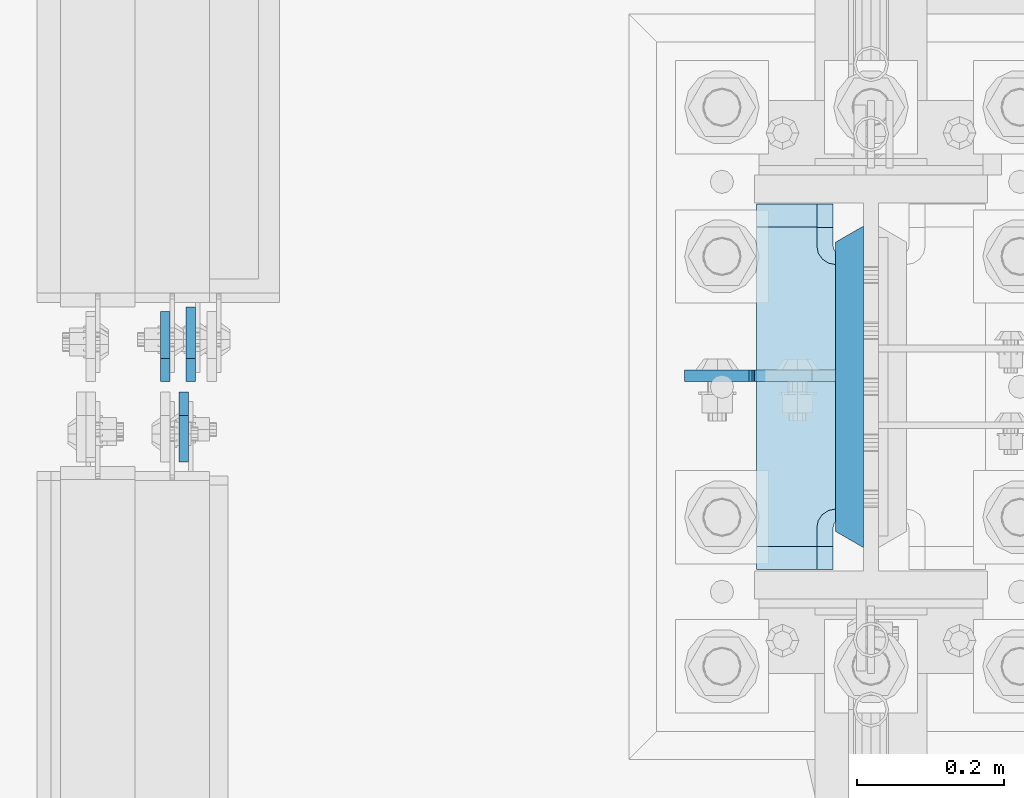
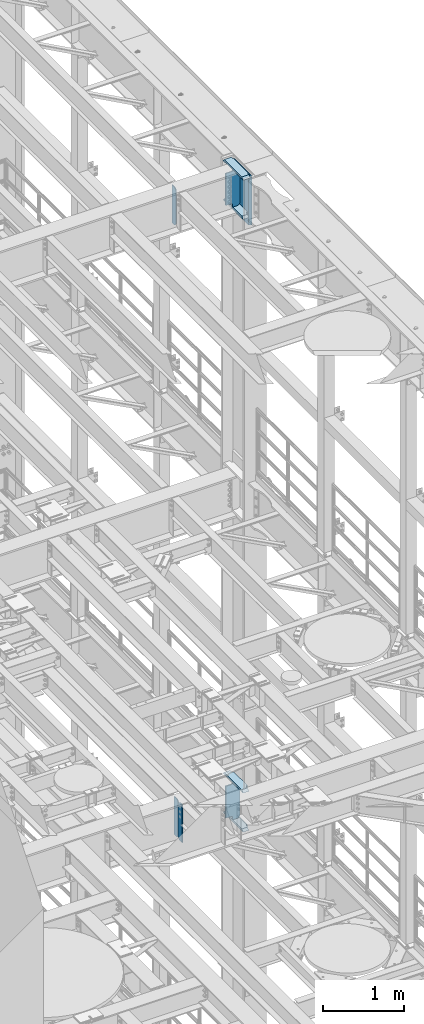
# One storey, part 1735 of 1876: 10 plates, 4 elements without a shape of their own.
"""IFC2X3 building model written with IfcOpenShell, lengths in millimetres."""

from ifc_helpers import new_model, si_unit, frame, origin_with_axes, place, context, subcontext, project, spatial, faceted_brep, material, type_object, element, aggregate, save


model = new_model("IFC2X3")

# Units and contexts
model_context = context("Model", 3, precision=1e-05, world=origin_with_axes())
body_context = subcontext(model_context, "Body", "Model", "MODEL_VIEW")
ifc_project = project(units=[si_unit("LENGTHUNIT", "METRE", prefix="MILLI"), si_unit("AREAUNIT", "SQUARE_METRE"), si_unit("VOLUMEUNIT", "CUBIC_METRE"), si_unit("MASSUNIT", "GRAM", prefix="KILO"), si_unit("TIMEUNIT", "SECOND"), si_unit("PLANEANGLEUNIT", "RADIAN"), si_unit("SOLIDANGLEUNIT", "STERADIAN"), si_unit("THERMODYNAMICTEMPERATUREUNIT", "DEGREE_CELSIUS"), si_unit("LUMINOUSINTENSITYUNIT", "LUMEN")], contexts=[model_context])

# Site, building, storey
site_placement = place(None, origin_with_axes())
site = spatial("IfcSite", under=ifc_project, at=site_placement, CompositionType="ELEMENT")
building_placement = place(site_placement, origin_with_axes())
building = spatial("IfcBuilding", under=site, at=building_placement, Name="Undefined", CompositionType="ELEMENT")
storey_placement = place(building_placement, origin_with_axes())
storey = spatial("IfcBuildingStorey", under=building, at=storey_placement, Name="Undefined", CompositionType="ELEMENT", Elevation=0.0)

# Assembly, plate
assembly_1_placement = place(storey_placement, origin_with_axes())
assembly_1 = element("IfcElementAssembly", 1, at=assembly_1_placement, inside=storey, Name="BEAM", AssemblyPlace="NOTDEFINED", PredefinedType="RIGID_FRAME")
ifc_material_1 = material(Name="STEEL/A36")
plate_type_1 = type_object("IfcPlateType", PredefinedType="NOTDEFINED")
plate_1_placement = place(assembly_1_placement, frame((6683.37499990463, 7612.85625, 12714.2875), z_axis=(0.0, 0.0, 1.0), x_axis=(0.0, -1.0, 0.0)))
plate_1 = element("IfcPlate", 2, at=plate_1_placement, type_object=plate_type_1, material=ifc_material_1, Name="PLATE", context=body_context, shape_type="Brep", body=[
    faceted_brep([(0.0, -6.34999999999991, 31.75), (0.0, -6.35000000000036, 538.162475585938), (0.0, 6.35000000000036, 538.162475585938), (0.0, 6.34999999999991, 31.75), (31.75, -6.35000000000036, 569.912475585938), (31.75, 6.35000000000036, 569.912475585938), (95.25, -6.35000000000036, 569.912475585938), (95.25, 6.35000000000036, 569.912475585938), (95.25, -6.35000000000036, 0.0), (95.25, 6.35000000000036, 0.0), (31.75, -6.34999999999991, 0.0), (31.75, 6.34999999999991, 0.0)], [[[0, 1, 2, 3]], [[1, 4, 5, 2]], [[4, 6, 7, 5]], [[6, 8, 9, 7]], [[8, 10, 11, 9]], [[10, 0, 3, 11]], [[5, 7, 9, 11, 3, 2]], [[10, 8, 6, 4, 1, 0]]]),
])

assembly_2_placement = place(storey_placement, origin_with_axes())
assembly_2 = element("IfcElementAssembly", 3, at=assembly_2_placement, inside=storey, Name="BEAM", AssemblyPlace="NOTDEFINED", PredefinedType="RIGID_FRAME")
plate_2_placement = place(assembly_2_placement, frame((6657.97499990463, 7627.14375, 21959.8875), z_axis=(0.0, 0.0, 1.0), x_axis=(0.0, 1.0, 0.0)))
plate_2 = element("IfcPlate", 4, at=plate_2_placement, type_object=plate_type_1, material=ifc_material_1, Name="PLATE", context=body_context, shape_type="Brep", body=[
    faceted_brep([(0.0, -6.34999999999991, 31.75), (0.0, -6.35000000000036, 538.162475585938), (0.0, 6.35000000000036, 538.162475585938), (0.0, 6.34999999999991, 31.75), (31.75, -6.35000000000036, 569.912475585938), (31.75, 6.35000000000036, 569.912475585938), (95.25, -6.35000000000036, 569.912475585938), (95.25, 6.35000000000036, 569.912475585938), (95.25, -6.35000000000036, 0.0), (95.25, 6.35000000000036, 0.0), (31.75, -6.34999999999991, 0.0), (31.75, 6.34999999999991, 0.0)], [[[0, 1, 2, 3]], [[1, 4, 5, 2]], [[4, 6, 7, 5]], [[6, 8, 9, 7]], [[8, 10, 11, 9]], [[10, 0, 3, 11]], [[5, 7, 9, 11, 3, 2]], [[10, 8, 6, 4, 1, 0]]]),
])
aggregate(assembly_2, [plate_2])

# Plate
plate_type_2 = type_object("IfcPlateType", PredefinedType="NOTDEFINED")
plate_3_placement = place(assembly_1_placement, frame((6692.89999990463, 7627.14375, 12714.2875), z_axis=(0.0, 0.0, 1.0), x_axis=(0.0, 1.0, 0.0)))
plate_3 = element("IfcPlate", 5, at=plate_3_placement, type_object=plate_type_2, material=ifc_material_1, Name="PLATE", context=body_context, shape_type="Brep", body=[
    faceted_brep([(0.0, -6.34999999999991, 31.75), (0.0, -6.35000000000036, 538.162475585938), (0.0, 6.35000000000036, 538.162475585938), (0.0, 6.34999999999991, 31.75), (31.75, -6.35000000000036, 569.912475585938), (31.75, 6.35000000000036, 569.912475585938), (101.599998474121, -6.34999999999991, 569.912475585938), (101.599998474121, 6.34999999999991, 569.912475585938), (101.599998474121, -6.35000000000036, 0.0), (101.599998474121, 6.35000000000036, 0.0), (31.75, -6.34999999999991, 0.0), (31.75, 6.34999999999991, 0.0)], [[[0, 1, 2, 3]], [[1, 4, 5, 2]], [[4, 6, 7, 5]], [[6, 8, 9, 7]], [[8, 10, 11, 9]], [[10, 0, 3, 11]], [[5, 7, 9, 11, 3, 2]], [[10, 8, 6, 4, 1, 0]]]),
])

aggregate(assembly_1, [plate_3, plate_1])

# Assembly, plates
assembly_3_placement = place(storey_placement, origin_with_axes())
assembly_3 = element("IfcElementAssembly", 6, at=assembly_3_placement, inside=storey, Name="COLUMN", AssemblyPlace="NOTDEFINED", PredefinedType="RIGID_FRAME")
ifc_material_2 = material(Name="STEEL/A572-GR.50")
plate_type_3 = type_object("IfcPlateType", PredefinedType="NOTDEFINED")
plate_4_placement = place(assembly_3_placement, frame((7590.63125, 7400.925, 22523.45), z_axis=(0.0, 1.0, 0.0), x_axis=(0.0, 0.0, -1.0)))
plate_4 = element("IfcPlate", 7, at=plate_4_placement, type_object=plate_type_3, material=ifc_material_2, Name="PLATE", context=body_context, shape_type="Brep", body=[
    faceted_brep([(0.0, 19.0500000000002, 416.152954742277), (0.0, -19.0500000000002, 438.149993896484), (742.950012207031, -19.0500000000002, 438.149993896484), (742.950012207031, 19.0500000000002, 416.152954742277), (742.950012207031, 19.0500000000002, 21.9970452577325), (0.0, 19.0500000000002, 21.9970452577367), (0.0, -19.0500000000002, 0.0), (742.950012207031, -19.0500000000002, 0.0)], [[[0, 1, 2, 3]], [[0, 3, 4, 5]], [[1, 0, 5, 6]], [[2, 1, 6, 7]], [[3, 2, 7, 4]], [[6, 5, 4, 7]]]),
])
ifc_material_3 = material(Name="STEEL/A572-50")
plate_type_4 = type_object("IfcPlateType", PredefinedType="NOTDEFINED")
plate_5_placement = place(assembly_3_placement, frame((7463.63125, 7869.2375, 21948.775012207), z_axis=(0.0, -1.0, 0.0), x_axis=(1.0, 0.0, 0.0)))
plate_5 = element("IfcPlate", 8, at=plate_5_placement, type_object=plate_type_4, material=ifc_material_3, Name="PLATE", context=body_context, shape_type="Brep", body=[
    faceted_brep([(82.5499973297119, -15.875, 498.475006103516), (82.5499973297119, 15.875, 467.025007631571), (0.0, 15.875, 467.025007631571), (0.0, -15.875, 498.475006103516), (82.5499973297119, 15.875, 31.449998471945), (82.5499973297119, -15.875, 0.0), (0.0, -15.875, 0.0), (0.0, 15.875, 31.449998471945), (82.5499973297119, 15.875, 57.1500034332275), (82.5499973297119, -15.875, 57.1500034332275), (84.4834571748879, -15.875, 66.8701624693188), (84.4834571748879, 15.875, 66.8701624693188), (89.9894849758439, -15.875, 75.1105154056261), (89.9894849758439, 15.875, 75.1105154056261), (98.2298379121512, -15.875, 80.616543206582), (98.2298379121512, 15.875, 80.616543206582), (107.949996948242, -15.875, 82.5500030517578), (107.949996948242, 15.875, 82.5500030517578), (107.949996948242, -15.875, 415.925003051758), (107.949996948242, 15.875, 415.925003051758), (98.2298379121512, -15.875, 417.858462896934), (98.2298379121512, 15.875, 417.858462896934), (89.9894849758439, -15.875, 423.36449069789), (89.9894849758439, 15.875, 423.36449069789), (84.483457174887, -15.875, 431.604843634197), (84.483457174887, 15.875, 431.604843634197), (82.5499973297119, -15.875, 441.325002670288), (82.5499973297119, 15.875, 441.325002670288)], [[[0, 1, 2, 3]], [[4, 5, 6, 7]], [[8, 9, 5, 4]], [[10, 9, 8, 11]], [[12, 10, 11, 13]], [[14, 12, 13, 15]], [[16, 14, 15, 17]], [[18, 16, 17, 19]], [[20, 18, 19, 21]], [[22, 20, 21, 23]], [[24, 22, 23, 25]], [[26, 24, 25, 27]], [[6, 5, 9, 10, 12, 14, 16, 18, 20, 22, 24, 26, 0, 3]], [[7, 6, 3, 2]], [[27, 25, 23, 21, 19, 17, 15, 13, 11, 8, 4, 7, 2, 1]], [[26, 27, 1, 0]]]),
])

assembly_4_placement = place(storey_placement, origin_with_axes())
assembly_4 = element("IfcElementAssembly", 9, at=assembly_4_placement, inside=storey, Name="COLUMN", AssemblyPlace="NOTDEFINED", PredefinedType="RIGID_FRAME")
plate_6_placement = place(assembly_4_placement, frame((7463.63125, 7869.2375, 12703.175012207), z_axis=(0.0, -1.0, 0.0), x_axis=(1.0, 0.0, 0.0)))
plate_6 = element("IfcPlate", 10, at=plate_6_placement, type_object=plate_type_4, material=ifc_material_3, Name="PLATE", context=body_context, shape_type="Brep", body=[
    faceted_brep([(82.5499973297119, -15.875, 498.475006103516), (82.5499973297119, 15.875, 467.025007631571), (0.0, 15.875, 467.025007631571), (0.0, -15.875, 498.475006103516), (82.5499973297119, 15.875, 31.449998471945), (82.5499973297119, -15.875, 0.0), (0.0, -15.875, 0.0), (0.0, 15.875, 31.449998471945), (82.5499973297119, 15.875, 57.1500034332275), (82.5499973297119, -15.875, 57.1500034332275), (84.4834571748879, -15.875, 66.8701624693188), (84.4834571748879, 15.875, 66.8701624693188), (89.9894849758439, -15.875, 75.1105154056261), (89.9894849758439, 15.875, 75.1105154056261), (98.2298379121512, -15.875, 80.616543206582), (98.2298379121512, 15.875, 80.616543206582), (107.949996948242, -15.875, 82.5500030517578), (107.949996948242, 15.875, 82.5500030517578), (107.949996948242, -15.875, 415.925003051758), (107.949996948242, 15.875, 415.925003051758), (98.2298379121512, -15.875, 417.858462896934), (98.2298379121512, 15.875, 417.858462896934), (89.9894849758439, -15.875, 423.36449069789), (89.9894849758439, 15.875, 423.36449069789), (84.483457174887, -15.875, 431.604843634197), (84.483457174887, 15.875, 431.604843634197), (82.5499973297119, -15.875, 441.325002670288), (82.5499973297119, 15.875, 441.325002670288)], [[[0, 1, 2, 3]], [[4, 5, 6, 7]], [[8, 9, 5, 4]], [[10, 9, 8, 11]], [[12, 10, 11, 13]], [[14, 12, 13, 15]], [[16, 14, 15, 17]], [[18, 16, 17, 19]], [[20, 18, 19, 21]], [[22, 20, 21, 23]], [[24, 22, 23, 25]], [[26, 24, 25, 27]], [[6, 5, 9, 10, 12, 14, 16, 18, 20, 22, 24, 26, 0, 3]], [[7, 6, 3, 2]], [[27, 25, 23, 21, 19, 17, 15, 13, 11, 8, 4, 7, 2, 1]], [[26, 27, 1, 0]]]),
])
plate_7_placement = place(assembly_4_placement, frame((7463.63125, 7869.2375, 13293.725), z_axis=(0.0, -1.0, 0.0), x_axis=(1.0, 0.0, 0.0)))
plate_7 = element("IfcPlate", 11, at=plate_7_placement, type_object=plate_type_4, material=ifc_material_3, Name="PLATE", context=body_context, shape_type="Brep", body=[
    faceted_brep([(82.5499973297119, -15.875, 498.475006103516), (82.5499973297119, 15.875, 467.025007631571), (0.0, 15.875, 467.025007631571), (0.0, -15.875, 498.475006103516), (82.5499973297119, 15.875, 31.449998471945), (82.5499973297119, -15.875, 0.0), (0.0, -15.875, 0.0), (0.0, 15.875, 31.449998471945), (82.5499973297119, 15.875, 57.1500034332275), (82.5499973297119, -15.875, 57.1500034332275), (84.4834571748879, -15.875, 66.8701624693188), (84.4834571748879, 15.875, 66.8701624693188), (89.9894849758439, -15.875, 75.1105154056261), (89.9894849758439, 15.875, 75.1105154056261), (98.2298379121512, -15.875, 80.616543206582), (98.2298379121512, 15.875, 80.616543206582), (107.949996948242, -15.875, 82.5500030517578), (107.949996948242, 15.875, 82.5500030517578), (107.949996948242, -15.875, 415.925003051758), (107.949996948242, 15.875, 415.925003051758), (98.2298379121512, -15.875, 417.858462896934), (98.2298379121512, 15.875, 417.858462896934), (89.9894849758439, -15.875, 423.36449069789), (89.9894849758439, 15.875, 423.36449069789), (84.483457174887, -15.875, 431.604843634197), (84.483457174887, 15.875, 431.604843634197), (82.5499973297119, -15.875, 441.325002670288), (82.5499973297119, 15.875, 441.325002670288)], [[[0, 1, 2, 3]], [[4, 5, 6, 7]], [[8, 9, 5, 4]], [[10, 9, 8, 11]], [[12, 10, 11, 13]], [[14, 12, 13, 15]], [[16, 14, 15, 17]], [[18, 16, 17, 19]], [[20, 18, 19, 21]], [[22, 20, 21, 23]], [[24, 22, 23, 25]], [[26, 24, 25, 27]], [[6, 5, 9, 10, 12, 14, 16, 18, 20, 22, 24, 26, 0, 3]], [[7, 6, 3, 2]], [[27, 25, 23, 21, 19, 17, 15, 13, 11, 8, 4, 7, 2, 1]], [[26, 27, 1, 0]]]),
])

# Plate
plate_type_5 = type_object("IfcPlateType", PredefinedType="NOTDEFINED")
plate_8_placement = place(assembly_3_placement, frame((7571.58125, 7635.08125, 22523.45), z_axis=(-1.0, 0.0, 0.0), x_axis=(0.0, 0.0, -1.0)))
plate_8 = element("IfcPlate", 12, at=plate_8_placement, type_object=plate_type_5, material=ifc_material_1, Name="PLATE", context=body_context, shape_type="Brep", body=[
    faceted_brep([(501.650012207032, -7.9375, 205.581252728631), (501.650012207032, -7.9375, 123.031246757509), (501.650012207032, 7.9375, 123.031246757509), (501.650012207032, 7.9375, 205.581253051758), (502.61674212962, -7.9375, 118.171167239463), (502.61674212962, 7.9375, 118.171167239463), (505.369756030097, -7.9375, 114.050990771309), (505.369756030097, 7.9375, 114.050990771309), (509.489932498251, -7.9375, 111.297976870831), (509.489932498251, 7.9375, 111.297976870831), (514.350012016297, -7.9375, 110.331246948243), (514.350012016297, 7.9375, 110.331246948243), (558.799987792969, -7.9375, 110.331246948243), (558.799987792969, 7.9375, 110.331246948243), (19.0499992370605, -7.9375, 205.58125), (19.0499992370605, 7.9375, 205.581253051758), (19.0499992370605, 7.9375, 123.031249809265), (19.0499992370605, -7.9375, 123.031249809265), (18.083269314473, 7.9375, 118.17117029122), (18.083269314473, -7.9375, 118.17117029122), (15.3302554139955, 7.9375, 114.050993823066), (15.3302554139955, -7.9375, 114.050993823066), (11.2100789458418, 7.9375, 111.297979922588), (11.2100789458418, -7.9375, 111.297979922588), (6.34999942779541, 7.9375, 110.33125), (6.34999942779541, -7.9375, 110.33125), (0.0, 7.9375, 110.33125), (0.0, -7.9375, 110.33125), (0.0, 7.93749999999999, 31.75), (0.0, -7.93749999999998, 31.75), (31.75, -7.93749999999998, 0.0), (31.75, 7.93749999999999, 0.0), (527.049987792969, -7.93749999999998, 0.0), (527.049987792969, 7.93749999999999, 0.0), (558.799987792969, -7.93749999999998, 31.75), (558.799987792969, 7.93749999999999, 31.75)], [[[0, 1, 2, 3]], [[4, 5, 2, 1]], [[6, 7, 5, 4]], [[8, 9, 7, 6]], [[10, 11, 9, 8]], [[12, 13, 11, 10]], [[14, 15, 16, 17]], [[17, 16, 18, 19]], [[19, 18, 20, 21]], [[21, 20, 22, 23]], [[23, 22, 24, 25]], [[25, 24, 26, 27]], [[28, 29, 27, 26]], [[30, 29, 28, 31]], [[32, 30, 31, 33]], [[34, 32, 33, 35]], [[8, 6, 4, 1, 0, 14, 17, 19, 21, 23, 25, 27, 29, 30, 32, 34, 12, 10]], [[15, 14, 0, 3]], [[35, 33, 31, 28, 26, 24, 22, 20, 18, 16, 15, 3, 2, 5, 7, 9, 11, 13]], [[34, 35, 13, 12]]]),
])

plate_9_placement = place(assembly_4_placement, frame((7571.58125, 7635.08125, 13277.85), z_axis=(-1.0, 0.0, 0.0), x_axis=(0.0, 0.0, -1.0)))
plate_9 = element("IfcPlate", 13, at=plate_9_placement, type_object=plate_type_5, material=ifc_material_1, Name="PLATE", context=body_context, shape_type="Brep", body=[
    faceted_brep([(501.650012207032, -7.9375, 205.581252728631), (501.650012207032, -7.9375, 123.031246757509), (501.650012207032, 7.9375, 123.031246757509), (501.650012207032, 7.9375, 205.581253051758), (502.61674212962, -7.9375, 118.171167239463), (502.61674212962, 7.9375, 118.171167239463), (505.369756030097, -7.9375, 114.050990771309), (505.369756030097, 7.9375, 114.050990771309), (509.489932498251, -7.9375, 111.297976870831), (509.489932498251, 7.9375, 111.297976870831), (514.350012016297, -7.9375, 110.331246948243), (514.350012016297, 7.9375, 110.331246948243), (558.799987792969, -7.9375, 110.331246948243), (558.799987792969, 7.9375, 110.331246948243), (19.0499992370605, -7.9375, 205.58125), (19.0499992370605, 7.9375, 205.581253051758), (19.0499992370605, 7.9375, 123.031249809265), (19.0499992370605, -7.9375, 123.031249809265), (18.083269314473, 7.9375, 118.17117029122), (18.083269314473, -7.9375, 118.17117029122), (15.3302554139955, 7.9375, 114.050993823066), (15.3302554139955, -7.9375, 114.050993823066), (11.2100789458418, 7.9375, 111.297979922588), (11.2100789458418, -7.9375, 111.297979922588), (6.34999942779541, 7.9375, 110.33125), (6.34999942779541, -7.9375, 110.33125), (0.0, 7.9375, 110.33125), (0.0, -7.9375, 110.33125), (0.0, 7.93749999999999, 31.75), (0.0, -7.93749999999998, 31.75), (31.75, -7.93749999999998, 0.0), (31.75, 7.93749999999999, 0.0), (527.049987792969, -7.93749999999998, 0.0), (527.049987792969, 7.93749999999999, 0.0), (558.799987792969, -7.93749999999998, 31.75), (558.799987792969, 7.93749999999999, 31.75)], [[[0, 1, 2, 3]], [[4, 5, 2, 1]], [[6, 7, 5, 4]], [[8, 9, 7, 6]], [[10, 11, 9, 8]], [[12, 13, 11, 10]], [[14, 15, 16, 17]], [[17, 16, 18, 19]], [[19, 18, 20, 21]], [[21, 20, 22, 23]], [[23, 22, 24, 25]], [[25, 24, 26, 27]], [[28, 29, 27, 26]], [[30, 29, 28, 31]], [[32, 30, 31, 33]], [[34, 32, 33, 35]], [[8, 6, 4, 1, 0, 14, 17, 19, 21, 23, 25, 27, 29, 30, 32, 34, 12, 10]], [[15, 14, 0, 3]], [[35, 33, 31, 28, 26, 24, 22, 20, 18, 16, 15, 3, 2, 5, 7, 9, 11, 13]], [[34, 35, 13, 12]]]),
])

aggregate(assembly_4, [plate_6, plate_7, plate_9])

plate_type_6 = type_object("IfcPlateType", PredefinedType="NOTDEFINED")
plate_10_placement = place(assembly_3_placement, frame((7463.63124694824, 7370.7625, 22539.325), z_axis=(0.0, 1.0, 0.0), x_axis=(1.0, 0.0, 0.0)))
plate_10 = element("IfcPlate", 14, at=plate_10_placement, type_object=plate_type_6, material=ifc_material_3, Name="PLATE", context=body_context, shape_type="Brep", body=[
    faceted_brep([(108.494745348945, -15.875, 66.1302546510551), (108.494745348945, 15.875, 66.1302546510551), (112.614921817099, 15.875, 68.8832685515335), (112.614921817099, -15.875, 68.8832685515335), (105.741731448466, -15.875, 62.0100781829015), (105.741731448466, 15.875, 62.0100781829015), (104.775001525879, -15.875, 57.149998664856), (104.775001525879, 15.875, 57.149998664856), (104.775001525879, -15.875, 31.75), (104.775001525879, 15.875, 0.0), (0.0, -15.875, 31.75), (0.0, 15.875, 0.0), (0.0, -15.875, 466.725006103516), (0.0, 15.875, 498.475006103516), (104.775001525879, -15.875, 466.725006103516), (104.775001525879, 15.875, 498.475006103516), (104.775001525879, -15.875, 441.325001335143), (104.775001525879, 15.875, 441.325001335143), (105.741731448466, -15.875, 436.464921817097), (105.741731448466, 15.875, 436.464921817097), (108.494745348945, -15.875, 432.344745348943), (108.494745348945, 15.875, 432.344745348943), (112.614921817099, -15.875, 429.591731448465), (112.614921817099, 15.875, 429.591731448465), (117.475001335144, 15.875, 69.8499984741211), (117.475001335144, 15.875, 428.625001525877), (146.050003051758, 15.875, 428.625001525877), (146.050003051758, 15.875, 69.8499984741211), (117.475001335144, -12.7000017166138, 69.8499984741211), (114.300003051756, -15.875, 69.2184520491464), (114.300003051756, -15.875, 429.256547950852), (117.475001335144, -12.7000017166138, 428.625001525877)], [[[0, 1, 2, 3]], [[4, 5, 1, 0]], [[6, 7, 5, 4]], [[8, 9, 7, 6]], [[10, 11, 9, 8]], [[11, 10, 12, 13]], [[13, 12, 14, 15]], [[15, 14, 16, 17]], [[18, 19, 17, 16]], [[20, 21, 19, 18]], [[22, 23, 21, 20]], [[24, 2, 1, 5, 7, 9, 11, 13, 15, 17, 19, 21, 23, 25, 26, 27]], [[24, 27, 28]], [[3, 2, 24, 28, 29]], [[22, 20, 18, 16, 14, 12, 10, 8, 6, 4, 0, 3, 29, 30]], [[25, 23, 22, 30, 31]], [[25, 31, 26]], [[30, 29, 28, 27, 26, 31]]]),
])

aggregate(assembly_3, [plate_5, plate_8, plate_4, plate_10])

save(model, "model.ifc")
